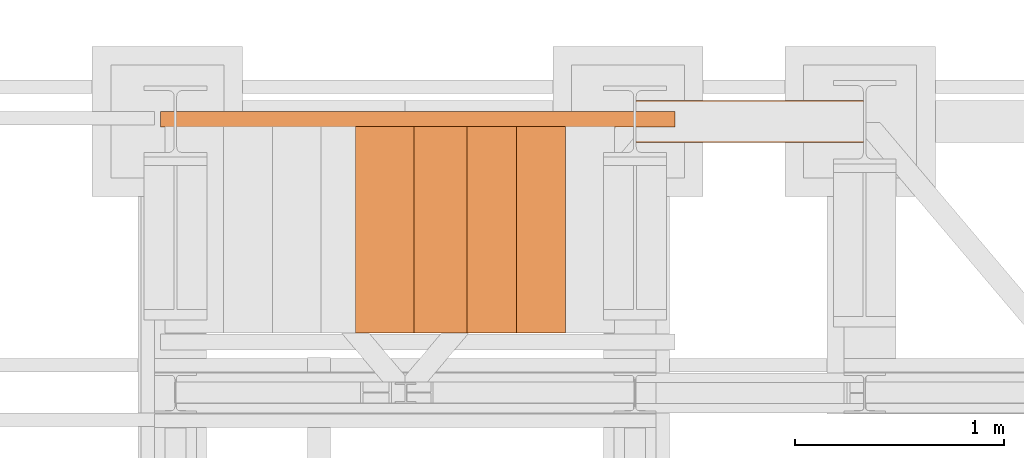
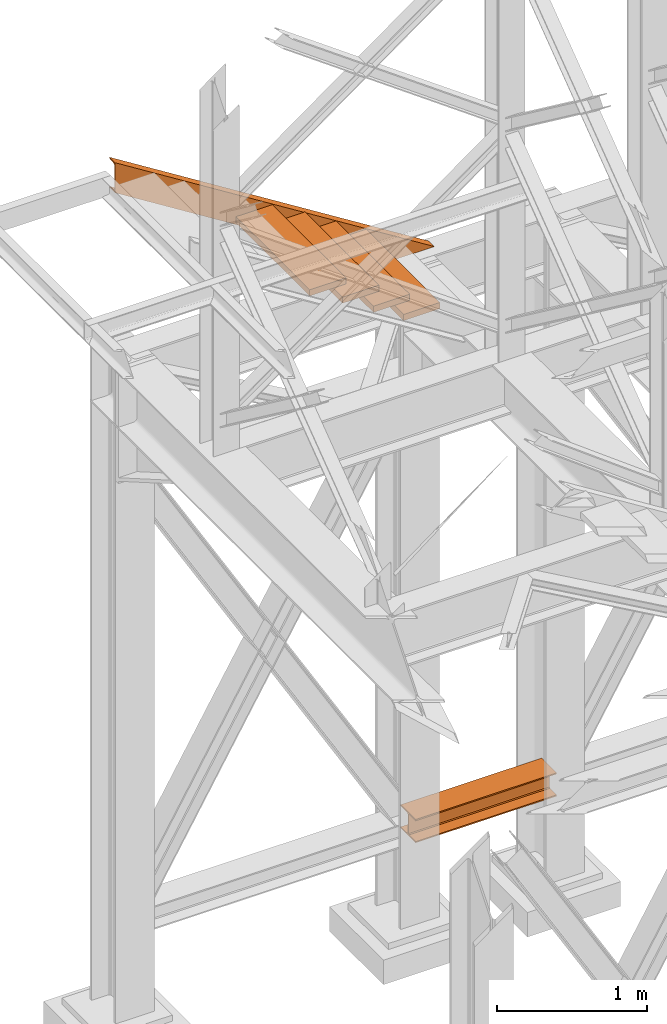
# One storey, part 135 of 208: 6 proxies.
"""IFC2X3 building model written with IfcOpenShell, lengths in millimetres."""

import ifcopenshell
import ifcopenshell.guid

model = None  # the IFC model being written
_history = None  # IfcOwnerHistory: only IFC2X3 demands one
_inside = {}  # id of a spatial element -> (the spatial element, [elements in it])
_under = {}  # id of a project, library or spatial element -> (it, [spatial elements below it])
_declared = {}  # id of a project -> (the project, [libraries it declares])
_typed = {}  # id of a type object -> (the type object, [elements of that type])
_made_of = {}  # id of a material, layer set ... -> (it, [elements and type objects made of it])


def new_model(schema):
    """Start an empty IFC model of exactly this schema.

    Asked for "IFC4X3", IfcOpenShell would pick the latest addendum, in which some entities
    have other attributes; the version numbers below select the first issue.
    IFC2X3 requires an IfcOwnerHistory on every rooted entity: one is made here for all.
    """
    global model, _history
    if schema == "IFC4X3":
        model = ifcopenshell.file(schema_version=(4, 3, 0, 0))
    else:
        model = ifcopenshell.file(schema=schema)
    _inside.clear()
    _under.clear()
    _declared.clear()
    _typed.clear()
    _made_of.clear()
    _history = None
    if model.schema == "IFC2X3":
        org = make("IfcOrganization", Name="unknown")
        user = make(
            "IfcPersonAndOrganization",
            ThePerson=make("IfcPerson", FamilyName="unknown"),
            TheOrganization=org,
        )
        app = make(
            "IfcApplication",
            ApplicationDeveloper=org,
            Version="unknown",
            ApplicationFullName="unknown",
            ApplicationIdentifier="unknown",
        )
        _history = make(
            "IfcOwnerHistory",
            OwningUser=user,
            OwningApplication=app,
            ChangeAction="ADDED",
            CreationDate=0,
        )
    return model


def make(cls, **values):
    """One entity of the class cls with the attributes given. An attribute that is None is left unset."""
    return model.create_entity(
        cls, **{name: value for name, value in values.items() if value is not None}
    )


def entity(cls, *values):
    """Any entity or typed value of the class cls, its attributes in the order of the schema. None: left unset."""
    e = model.create_entity(cls)
    for i, value in enumerate(values):
        if value is not None:
            e[i] = value
    return e


def rooted(cls, **values):
    """An entity with a GlobalId (a new one), such as an element, a storey or a relation."""
    return make(cls, GlobalId=ifcopenshell.guid.new(), OwnerHistory=_history, **values)


def si_unit(unit_type, name, prefix=None):
    """IfcSIUnit, for example si_unit("LENGTHUNIT", "METRE", prefix="MILLI")."""
    return make("IfcSIUnit", UnitType=unit_type, Prefix=prefix, Name=name)


def converted_unit(unit_type, name, factor, base, dimensions=None, offset=None):
    """IfcConversionBasedUnit, such as the inch: factor (a typed value) times the base unit."""
    return make(
        "IfcConversionBasedUnit"
        if offset is None
        else "IfcConversionBasedUnitWithOffset",
        ConversionOffset=offset,
        Dimensions=None
        if dimensions is None
        else entity("IfcDimensionalExponents", *dimensions),
        UnitType=unit_type,
        Name=name,
        ConversionFactor=make(
            "IfcMeasureWithUnit", ValueComponent=factor, UnitComponent=base
        ),
    )


def assignment(units):
    """IfcUnitAssignment: the units of a project."""
    return None if units is None else make("IfcUnitAssignment", Units=units)


def point(xyz):
    """IfcCartesianPoint."""
    return None if xyz is None else make("IfcCartesianPoint", Coordinates=xyz)


def direction(xyz):
    """IfcDirection."""
    return None if xyz is None else make("IfcDirection", DirectionRatios=xyz)


def frame(location, z_axis=None, x_axis=None):
    """IfcAxis2Placement3D, a coordinate frame: its origin and axes. An axis left out is left unset."""
    return make(
        "IfcAxis2Placement3D",
        Location=point(location),
        Axis=direction(z_axis),
        RefDirection=direction(x_axis),
    )


def origin():
    """The frame at (0, 0, 0) with its axes left unset."""
    return frame((0.0, 0.0, 0.0))


def origin_with_axes():
    """The frame at (0, 0, 0) with the z axis (0, 0, 1) and the x axis (1, 0, 0) written out."""
    return frame((0.0, 0.0, 0.0), z_axis=(0.0, 0.0, 1.0), x_axis=(1.0, 0.0, 0.0))


def place(relative_to, where):
    """IfcLocalPlacement: puts the frame where relative to a parent placement (None: the world)."""
    return make(
        "IfcLocalPlacement", PlacementRelTo=relative_to, RelativePlacement=where
    )


def context(
    kind, dimensions, precision=None, world=None, true_north=None, identifier=None
):
    """IfcGeometricRepresentationContext, for example the 3D "Model" context."""
    return make(
        "IfcGeometricRepresentationContext",
        ContextIdentifier=identifier,
        ContextType=kind,
        CoordinateSpaceDimension=dimensions,
        Precision=precision,
        WorldCoordinateSystem=world,
        TrueNorth=true_north,
    )


def subcontext(parent, identifier, kind, view, scale=None):
    """IfcGeometricRepresentationSubContext, for example "Body" below "Model"."""
    return make(
        "IfcGeometricRepresentationSubContext",
        ContextIdentifier=identifier,
        ContextType=kind,
        ParentContext=parent,
        TargetScale=scale,
        TargetView=view,
    )


def project(units=None, contexts=None):
    """IfcProject with its units and contexts."""
    return rooted(
        "IfcProject",
        Name="project",
        RepresentationContexts=contexts,
        UnitsInContext=assignment(units),
    )


def spatial(cls, under=None, at=None, **own):
    """A site, building, storey or space (cls), placed at a placement, below another one or the project."""
    s = rooted(cls, ObjectPlacement=at, **own)
    if under is not None:
        _under.setdefault(under.id(), (under, []))[1].append(s)
    return s


def faces_of(points, faces, orient=None, outer=None):
    """IfcFace entities. A face is a list of loops; a loop is a list of indices into points, from 0.

    orient and outer hold one flag for each loop. By default every Orientation is true, the
    first loop of a face is its IfcFaceOuterBound and the others are IfcFaceBound.
    """
    made = []
    for i, loops in enumerate(faces):
        bounds = []
        for j, loop in enumerate(loops):
            is_outer = j == 0 if outer is None else outer[i][j]
            bounds.append(
                make(
                    "IfcFaceOuterBound" if is_outer else "IfcFaceBound",
                    Bound=make("IfcPolyLoop", Polygon=[points[k] for k in loop]),
                    Orientation=True if orient is None else orient[i][j],
                )
            )
        made.append(make("IfcFace", Bounds=bounds))
    return made


def faceted_brep(points, faces, orient=None, outer=None, voids=None):
    """IfcFacetedBrep: a solid bounded by flat faces; with voids (closed shells), ...WithVoids."""
    shared = [point(p) for p in points]
    hull = make("IfcClosedShell", CfsFaces=faces_of(shared, faces, orient, outer))
    if voids is None:
        return make("IfcFacetedBrep", Outer=hull)
    return make(
        "IfcFacetedBrepWithVoids",
        Outer=hull,
        Voids=[
            make(cls, CfsFaces=faces_of(shared, fs, o, b)) for cls, fs, o, b in voids
        ],
    )


def shape(context_of_items, identifier, shape_type, items):
    """IfcShapeRepresentation: the items that make up one representation, for example the "Body"."""
    return make(
        "IfcShapeRepresentation",
        ContextOfItems=context_of_items,
        RepresentationIdentifier=identifier,
        RepresentationType=shape_type,
        Items=items,
    )


def made_of(thing, what):
    """Note that an element or type object is made of a material, layer set ...; save() writes the relation."""
    if what is not None:
        _made_of.setdefault(what.id(), (what, []))[1].append(thing)
    return thing


def element(
    cls,
    number,
    at=None,
    inside=None,
    cuts=None,
    type_object=None,
    material=None,
    context=None,
    identifier="Body",
    shape_type=None,
    held_by="IfcProductDefinitionShape",
    body=None,
    shapes=None,
    **own,
):
    """One element of the class cls, such as IfcWall. Its Tag is "e" and its number.

    at: its placement. inside: the storey or other place that contains it. cuts: it is an
    opening in that element (IfcRelVoidsElement). A single representation is given by context,
    identifier, shape_type and body (its items); several are given by shapes. held_by: the class
    of the entity that holds the representations. save() writes the other relations.
    """
    e = rooted(cls, Tag="e%d" % number, ObjectPlacement=at, **own)
    if body is not None:
        shapes = [shape(context, identifier, shape_type, body)]
    if shapes is not None:
        e.Representation = make(held_by, Representations=shapes)
    if inside is not None:
        _inside.setdefault(inside.id(), (inside, []))[1].append(e)
    if cuts is not None:
        rooted(
            "IfcRelVoidsElement", RelatingBuildingElement=cuts, RelatedOpeningElement=e
        )
    if type_object is not None:
        _typed.setdefault(type_object.id(), (type_object, []))[1].append(e)
    return made_of(e, material)


def aggregate(whole, parts):
    """IfcRelAggregates: a whole, such as a stair, and the parts it consists of."""
    return rooted("IfcRelAggregates", RelatingObject=whole, RelatedObjects=parts)


def save(model, path):
    """Write the relations noted so far, then the file.

    IfcRelAggregates (storeys below a building ...), IfcRelContainedInSpatialStructure (elements
    in a storey), IfcRelDefinesByType, IfcRelAssociatesMaterial and IfcRelDeclares: one each for
    every whole, place, type object, material and project.
    """
    for whole, parts in _under.values():
        aggregate(whole, parts)
    for where, things in _inside.values():
        rooted(
            "IfcRelContainedInSpatialStructure",
            RelatedElements=things,
            RelatingStructure=where,
        )
    for kind, things in _typed.values():
        rooted("IfcRelDefinesByType", RelatedObjects=things, RelatingType=kind)
    for what, things in _made_of.values():
        rooted("IfcRelAssociatesMaterial", RelatedObjects=things, RelatingMaterial=what)
    for by, libraries in _declared.values():
        rooted("IfcRelDeclares", RelatingContext=by, RelatedDefinitions=libraries)
    model.write(path)


model = new_model("IFC2X3")

# Units and contexts
model_context = context("Model", 3, precision=1e-05, world=origin())
plan_context = context("Plan", 3, precision=1e-05, world=origin())
body_context = subcontext(model_context, "Body", "Model", "MODEL_VIEW")
ifc_project = project(units=[si_unit("LENGTHUNIT", "METRE", prefix="MILLI"), converted_unit("PLANEANGLEUNIT", "DEGREE", entity("IfcPlaneAngleMeasure", 0.0174532925199433), si_unit("PLANEANGLEUNIT", "RADIAN"), dimensions=[0, 0, 0, 0, 0, 0, 0]), si_unit("AREAUNIT", "SQUARE_METRE"), si_unit("VOLUMEUNIT", "CUBIC_METRE")], contexts=[model_context, plan_context])

# Building, storey
building_placement = place(None, origin())
building = spatial("IfcBuilding", under=ifc_project, at=building_placement, CompositionType="COMPLEX")
storey_placement = place(building_placement, origin_with_axes())
storey = spatial("IfcBuildingStorey", under=building, at=storey_placement, Name="Geschoss", CompositionType="ELEMENT")

# Proxies
proxy_1_placement = place(storey_placement, frame((-1100.745031419175, -12562.57439501763, 544.9900024165573), z_axis=(0.0, 0.0, 1.0), x_axis=(1.0, 0.0, 0.0)))
element("IfcBuildingElementProxy", 1, at=proxy_1_placement, inside=storey, context=body_context, shape_type="Brep", body=[
    faceted_brep([(1088.009999895692, 0.01000000000021828, 190.0100125169755), (1088.009999895692, 200.0100029802325, 190.0100125169755), (1088.009999895692, 200.0100029802325, 180.0100146031381), (1088.009999895692, 121.2600035762789, 180.0100071525575), (1088.009999895692, 111.9441915473344, 178.1454621052743), (1088.009999895692, 105.1245498640838, 171.3258190250398), (1088.009999895692, 103.2600015571716, 162.0100079274179), (1088.009999895692, 103.2600015571716, 28.00999713897716), (1088.009999895692, 105.1245498640838, 18.69418604135524), (1088.009999895692, 111.9441915473344, 11.87454296112071), (1088.009999895692, 121.2600035762789, 10.00999791383754), (1088.009999895692, 200.0100029802325, 10.00999791383754), (1088.009999895692, 200.0100029802325, 0.01000000000010459), (1088.009999895692, 0.01000000000021828, 0.01000000000010459), (1088.009999895692, 0.01000000000021828, 10.00999791383754), (1088.009999895692, 78.75999940395377, 10.00999791383754), (1088.009999895692, 88.07581143289826, 11.87454296112071), (1088.009999895692, 94.89545311614893, 18.69418604135524), (1088.009999895692, 96.76000142306111, 28.00999713897716), (1088.009999895692, 96.76000142306111, 162.0100079274179), (1088.009999895692, 94.89545311614893, 171.3258190250398), (1088.009999895692, 88.07581143289826, 178.1454621052743), (1088.009999895692, 78.75999940395377, 180.0100071525575), (1088.009999895692, 0.01000000000021828, 180.0100146031381), (1088.009999895692, 200.0100029802325, 190.0100125169755), (1088.009999895692, 0.01000000000021828, 190.0100125169755), (0.009999999999990905, 0.01000000000021828, 190.0100125169754), (0.009999999999990905, 200.0100029802325, 190.0100125169754), (1088.009999895692, 200.0100029802325, 180.0100146031381), (1088.009999895692, 200.0100029802325, 190.0100125169755), (0.009999999999990905, 200.0100029802325, 190.0100125169754), (0.009999999999990905, 200.0100029802325, 180.010014603138), (1088.009999895692, 121.2600035762789, 180.0100071525575), (1088.009999895692, 200.0100029802325, 180.0100146031381), (0.009999999999990905, 200.0100029802325, 180.010014603138), (0.009999999999990905, 121.2600035762789, 180.0100071525574), (1088.009999895692, 111.9441915473344, 178.1454621052743), (1088.009999895692, 121.2600035762789, 180.0100071525575), (0.009999999999990905, 121.2600035762789, 180.0100071525574), (0.009999999999990905, 111.9441915473344, 178.1454621052742), (1088.009999895692, 105.1245498640838, 171.3258190250398), (1088.009999895692, 111.9441915473344, 178.1454621052743), (0.009999999999990905, 111.9441915473344, 178.1454621052742), (0.009999999999990905, 105.1245498640838, 171.3258190250397), (1088.009999895692, 103.2600015571716, 162.0100079274179), (1088.009999895692, 105.1245498640838, 171.3258190250398), (0.009999999999990905, 105.1245498640838, 171.3258190250397), (0.009999999999990905, 103.2600015571716, 162.0100079274178), (1088.009999895692, 103.2600015571716, 28.00999713897716), (1088.009999895692, 103.2600015571716, 162.0100079274179), (0.009999999999990905, 103.2600015571716, 162.0100079274178), (0.009999999999990905, 103.2600015571716, 28.00999713897704), (1088.009999895692, 105.1245498640838, 18.69418604135524), (1088.009999895692, 103.2600015571716, 28.00999713897716), (0.009999999999990905, 103.2600015571716, 28.00999713897704), (0.009999999999990905, 105.1245498640838, 18.69418604135512), (1088.009999895692, 111.9441915473344, 11.87454296112071), (1088.009999895692, 105.1245498640838, 18.69418604135524), (0.009999999999990905, 105.1245498640838, 18.69418604135512), (0.009999999999990905, 111.9441915473344, 11.8745429611206), (1088.009999895692, 121.2600035762789, 10.00999791383754), (1088.009999895692, 111.9441915473344, 11.87454296112071), (0.009999999999990905, 111.9441915473344, 11.8745429611206), (0.009999999999990905, 121.2600035762789, 10.00999791383742), (1088.009999895692, 200.0100029802325, 10.00999791383754), (1088.009999895692, 121.2600035762789, 10.00999791383754), (0.009999999999990905, 121.2600035762789, 10.00999791383742), (0.009999999999990905, 200.0100029802325, 10.00999791383742), (1088.009999895692, 200.0100029802325, 0.01000000000010459), (1088.009999895692, 200.0100029802325, 10.00999791383754), (0.009999999999990905, 200.0100029802325, 10.00999791383742), (0.009999999999990905, 200.0100029802325, 0.009999999999990905), (1088.009999895692, 0.01000000000021828, 0.01000000000010459), (1088.009999895692, 200.0100029802325, 0.01000000000010459), (0.009999999999990905, 200.0100029802325, 0.009999999999990905), (0.009999999999990905, 0.01000000000021828, 0.009999999999990905), (1088.009999895692, 0.01000000000021828, 10.00999791383754), (1088.009999895692, 0.01000000000021828, 0.01000000000010459), (0.009999999999990905, 0.01000000000021828, 0.009999999999990905), (0.009999999999990905, 0.01000000000021828, 10.00999791383742), (1088.009999895692, 78.75999940395377, 10.00999791383754), (1088.009999895692, 0.01000000000021828, 10.00999791383754), (0.009999999999990905, 0.01000000000021828, 10.00999791383742), (0.009999999999990905, 78.75999940395377, 10.00999791383742), (1088.009999895692, 88.07581143289826, 11.87454296112071), (1088.009999895692, 78.75999940395377, 10.00999791383754), (0.009999999999990905, 78.75999940395377, 10.00999791383742), (0.009999999999990905, 88.07581143289826, 11.8745429611206), (1088.009999895692, 94.89545311614893, 18.69418604135524), (1088.009999895692, 88.07581143289826, 11.87454296112071), (0.009999999999990905, 88.07581143289826, 11.8745429611206), (0.009999999999990905, 94.89545311614893, 18.69418604135512), (1088.009999895692, 96.76000142306111, 28.00999713897716), (1088.009999895692, 94.89545311614893, 18.69418604135524), (0.009999999999990905, 94.89545311614893, 18.69418604135512), (0.009999999999990905, 96.76000142306111, 28.00999713897704), (1088.009999895692, 96.76000142306111, 162.0100079274179), (1088.009999895692, 96.76000142306111, 28.00999713897716), (0.009999999999990905, 96.76000142306111, 28.00999713897704), (0.009999999999990905, 96.76000142306111, 162.0100079274178), (1088.009999895692, 94.89545311614893, 171.3258190250398), (1088.009999895692, 96.76000142306111, 162.0100079274179), (0.009999999999990905, 96.76000142306111, 162.0100079274178), (0.009999999999990905, 94.89545311614893, 171.3258190250397), (1088.009999895692, 88.07581143289826, 178.1454621052743), (1088.009999895692, 94.89545311614893, 171.3258190250398), (0.009999999999990905, 94.89545311614893, 171.3258190250397), (0.009999999999990905, 88.07581143289826, 178.1454621052742), (1088.009999895692, 78.75999940395377, 180.0100071525575), (1088.009999895692, 88.07581143289826, 178.1454621052743), (0.009999999999990905, 88.07581143289826, 178.1454621052742), (0.009999999999990905, 78.75999940395377, 180.0100071525574), (1088.009999895692, 0.01000000000021828, 180.0100146031381), (1088.009999895692, 78.75999940395377, 180.0100071525575), (0.009999999999990905, 78.75999940395377, 180.0100071525574), (0.009999999999990905, 0.01000000000021828, 180.010014603138), (1088.009999895692, 0.01000000000021828, 190.0100125169755), (1088.009999895692, 0.01000000000021828, 180.0100146031381), (0.009999999999990905, 0.01000000000021828, 180.010014603138), (0.009999999999990905, 0.01000000000021828, 190.0100125169754), (0.009999999999990905, 0.01000000000021828, 190.0100125169754), (0.009999999999990905, 0.01000000000021828, 180.010014603138), (0.009999999999990905, 78.75999940395377, 180.0100071525574), (0.009999999999990905, 88.07581143289826, 178.1454621052742), (0.009999999999990905, 94.89545311614893, 171.3258190250397), (0.009999999999990905, 96.76000142306111, 162.0100079274178), (0.009999999999990905, 96.76000142306111, 28.00999713897704), (0.009999999999990905, 94.89545311614893, 18.69418604135512), (0.009999999999990905, 88.07581143289826, 11.8745429611206), (0.009999999999990905, 78.75999940395377, 10.00999791383742), (0.009999999999990905, 0.01000000000021828, 10.00999791383742), (0.009999999999990905, 0.01000000000021828, 0.009999999999990905), (0.009999999999990905, 200.0100029802325, 0.009999999999990905), (0.009999999999990905, 200.0100029802325, 10.00999791383742), (0.009999999999990905, 121.2600035762789, 10.00999791383742), (0.009999999999990905, 111.9441915473344, 11.8745429611206), (0.009999999999990905, 105.1245498640838, 18.69418604135512), (0.009999999999990905, 103.2600015571716, 28.00999713897704), (0.009999999999990905, 103.2600015571716, 162.0100079274178), (0.009999999999990905, 105.1245498640838, 171.3258190250397), (0.009999999999990905, 111.9441915473344, 178.1454621052742), (0.009999999999990905, 121.2600035762789, 180.0100071525574), (0.009999999999990905, 200.0100029802325, 180.010014603138), (0.009999999999990905, 200.0100029802325, 190.0100125169754)], [[[0, 1, 2, 3, 4, 5, 6, 7, 8, 9, 10, 11, 12, 13, 14, 15, 16, 17, 18, 19, 20, 21, 22, 23]], [[24, 25, 26, 27]], [[28, 29, 30, 31]], [[32, 33, 34, 35]], [[36, 37, 38, 39]], [[40, 41, 42, 43]], [[44, 45, 46, 47]], [[48, 49, 50, 51]], [[52, 53, 54, 55]], [[56, 57, 58, 59]], [[60, 61, 62, 63]], [[64, 65, 66, 67]], [[68, 69, 70, 71]], [[72, 73, 74, 75]], [[76, 77, 78, 79]], [[80, 81, 82, 83]], [[84, 85, 86, 87]], [[88, 89, 90, 91]], [[92, 93, 94, 95]], [[96, 97, 98, 99]], [[100, 101, 102, 103]], [[104, 105, 106, 107]], [[108, 109, 110, 111]], [[112, 113, 114, 115]], [[116, 117, 118, 119]], [[120, 121, 122, 123, 124, 125, 126, 127, 128, 129, 130, 131, 132, 133, 134, 135, 136, 137, 138, 139, 140, 141, 142, 143]]], orient=[[False], [False], [False], [False], [False], [False], [False], [False], [False], [False], [False], [False], [False], [False], [False], [False], [False], [False], [False], [False], [False], [False], [False], [False], [False], [False]]),
])
proxy_2_placement = place(storey_placement, frame((-3377.982231929545, -12489.73706339187, 5299.235995667714), z_axis=(0.0, 0.0, 1.0), x_axis=(1.0, 0.0, 0.0)))
element("IfcBuildingElementProxy", 2, at=proxy_2_placement, inside=storey, context=body_context, shape_type="Brep", body=[
    faceted_brep([(0.01000000000021828, 0.01000000000021828, 1301.03525473074), (0.01000000000021828, 0.01000000000021828, 1546.598640795312), (2463.776225798724, 0.01000000000021828, 0.01000000000294676), (2072.585730200911, 0.01000000000021828, 0.01000000000294676), (0.01000000000021828, 0.01000000000021828, 1546.598640795312), (0.01000000000021828, 75.01000111758731, 1546.598640795312), (2463.776225798724, 75.01000111758731, 0.01000000000294676), (2463.776225798724, 0.01000000000021828, 0.01000000000294676), (0.01000000000021828, 75.01000111758731, 1546.598640795312), (0.01000000000021828, 75.01000111758731, 1542.963282509619), (2457.984981296655, 75.01000111758731, 0.01000000000294676), (2463.776225798724, 75.01000111758731, 0.01000000000294676), (0.01000000000021828, 75.01000111758731, 1542.963282509619), (0.01000000000021828, 73.89400100171588, 1537.56333977627), (2449.382696127384, 73.89400100171588, 0.01000000000203727), (2457.984981296655, 75.01000111758731, 0.01000000000294676), (0.01000000000021828, 73.89400100171588, 1537.56333977627), (0.01000000000021828, 69.48847269475482, 1535.619839744783), (2446.28663709067, 69.48847269475482, 0.01000000000385626), (2449.382696127384, 73.89400100171588, 0.01000000000203727), (0.01000000000021828, 69.48847269475482, 1535.619839744783), (0.01000000000021828, 19.09293180167697, 1530.66971995284), (2438.400934561024, 19.09293180167697, 0.01000000000294676), (2446.28663709067, 69.48847269475482, 0.01000000000385626), (0.01000000000021828, 19.09293180167697, 1530.66971995284), (0.01000000000021828, 13.35380079060815, 1528.711080065991), (2435.280757240155, 13.35380079060815, 0.01000000000021828), (2438.400934561024, 19.09293180167697, 0.01000000000294676), (0.01000000000021828, 13.35380079060815, 1528.711080065991), (0.01000000000021828, 9.50015002697728, 1523.455656628751), (2426.908696030465, 9.50015002697728, 0.01000000000294676), (2435.280757240155, 13.35380079060815, 0.01000000000021828), (0.01000000000021828, 9.50015002697728, 1523.455656628751), (0.01000000000021828, 8.510000461936215, 1516.594795610196), (2415.979120310368, 8.510000461936215, 0.01000000000294676), (2426.908696030465, 9.50015002697728, 0.01000000000294676), (0.01000000000021828, 8.510000461936215, 1516.594795610196), (0.01000000000021828, 8.510000461936215, 1331.039099915858), (2120.382835689267, 8.510000461936215, 0.01000000000294676), (2415.979120310368, 8.510000461936215, 0.01000000000294676), (0.01000000000021828, 8.510000461936215, 1331.039099915858), (0.01000000000021828, 9.50015002697728, 1324.178238897302), (2109.453259969165, 9.50015002697728, 0.01000000000294676), (2120.382835689267, 8.510000461936215, 0.01000000000294676), (0.01000000000021828, 9.50015002697728, 1324.178238897302), (0.01000000000021828, 13.35380079060815, 1318.922815460061), (2101.081198759479, 13.35380079060815, 0.01000000000294676), (2109.453259969165, 9.50015002697728, 0.01000000000294676), (0.01000000000021828, 13.35380079060815, 1318.922815460061), (0.01000000000021828, 19.09293180167697, 1316.964175573211), (2097.96102143861, 19.09293180167697, 0.01000000000385626), (2101.081198759479, 13.35380079060815, 0.01000000000294676), (0.01000000000021828, 19.09293180167697, 1316.964175573211), (0.01000000000021828, 69.48847269475482, 1312.014055781273), (2090.075318908967, 69.48847269475482, 0.01000000000203727), (2097.96102143861, 19.09293180167697, 0.01000000000385626), (0.01000000000021828, 69.48847269475482, 1312.014055781273), (0.01000000000021828, 73.89400100171588, 1310.070555749785), (2086.97925987225, 73.89400100171588, 0.01000000000476575), (2090.075318908967, 69.48847269475482, 0.01000000000203727), (0.01000000000021828, 73.89400100171588, 1310.070555749785), (0.01000000000021828, 75.01000111758731, 1304.670613016434), (2078.376974702981, 75.01000111758731, 0.01000000000294676), (2086.97925987225, 73.89400100171588, 0.01000000000476575), (0.01000000000021828, 75.01000111758731, 1304.670613016434), (0.01000000000021828, 75.01000111758731, 1301.03525473074), (2072.585730200911, 75.01000111758731, 0.01000000000294676), (2078.376974702981, 75.01000111758731, 0.01000000000294676), (0.01000000000021828, 75.01000111758731, 1301.03525473074), (0.01000000000021828, 0.01000000000021828, 1301.03525473074), (2072.585730200911, 0.01000000000021828, 0.01000000000294676), (2072.585730200911, 75.01000111758731, 0.01000000000294676), (0.01000000000021828, 0.01000000000021828, 1301.03525473074), (0.01000000000021828, 75.01000111758731, 1301.03525473074), (0.01000000000021828, 75.01000111758731, 1304.670613016434), (0.01000000000021828, 73.89400100171588, 1310.070555749785), (0.01000000000021828, 69.48847269475482, 1312.014055781273), (0.01000000000021828, 19.09293180167697, 1316.964175573211), (0.01000000000021828, 13.35380079060815, 1318.922815460061), (0.01000000000021828, 9.50015002697728, 1324.178238897302), (0.01000000000021828, 8.510000461936215, 1331.039099915858), (0.01000000000021828, 8.510000461936215, 1516.594795610196), (0.01000000000021828, 9.50015002697728, 1523.455656628751), (0.01000000000021828, 13.35380079060815, 1528.711080065991), (0.01000000000021828, 19.09293180167697, 1530.66971995284), (0.01000000000021828, 69.48847269475482, 1535.619839744783), (0.01000000000021828, 73.89400100171588, 1537.56333977627), (0.01000000000021828, 75.01000111758731, 1542.963282509619), (0.01000000000021828, 75.01000111758731, 1546.598640795312), (0.01000000000021828, 0.01000000000021828, 1546.598640795312), (2072.585730200911, 0.01000000000021828, 0.01000000000294676), (2463.776225798724, 0.01000000000021828, 0.01000000000294676), (2463.776225798724, 75.01000111758731, 0.01000000000294676), (2457.984981296655, 75.01000111758731, 0.01000000000294676), (2449.382696127384, 73.89400100171588, 0.01000000000203727), (2446.28663709067, 69.48847269475482, 0.01000000000385626), (2438.400934561024, 19.09293180167697, 0.01000000000294676), (2435.280757240155, 13.35380079060815, 0.01000000000021828), (2426.908696030465, 9.50015002697728, 0.01000000000294676), (2415.979120310368, 8.510000461936215, 0.01000000000294676), (2120.382835689267, 8.510000461936215, 0.01000000000294676), (2109.453259969165, 9.50015002697728, 0.01000000000294676), (2101.081198759479, 13.35380079060815, 0.01000000000294676), (2097.96102143861, 19.09293180167697, 0.01000000000385626), (2090.075318908967, 69.48847269475482, 0.01000000000203727), (2086.97925987225, 73.89400100171588, 0.01000000000476575), (2078.376974702981, 75.01000111758731, 0.01000000000294676), (2072.585730200911, 75.01000111758731, 0.01000000000294676)], [[[0, 1, 2, 3]], [[4, 5, 6, 7]], [[8, 9, 10, 11]], [[12, 13, 14, 15]], [[16, 17, 18, 19]], [[20, 21, 22, 23]], [[24, 25, 26, 27]], [[28, 29, 30, 31]], [[32, 33, 34, 35]], [[36, 37, 38, 39]], [[40, 41, 42, 43]], [[44, 45, 46, 47]], [[48, 49, 50, 51]], [[52, 53, 54, 55]], [[56, 57, 58, 59]], [[60, 61, 62, 63]], [[64, 65, 66, 67]], [[68, 69, 70, 71]], [[72, 73, 74, 75, 76, 77, 78, 79, 80, 81, 82, 83, 84, 85, 86, 87, 88, 89]], [[90, 91, 92, 93, 94, 95, 96, 97, 98, 99, 100, 101, 102, 103, 104, 105, 106, 107]]], orient=[[False], [False], [False], [False], [False], [False], [False], [False], [False], [False], [False], [False], [False], [False], [False], [False], [False], [False], [False], [False]]),
])
proxy_3_placement = place(storey_placement, frame((-2191.97451080468, -13474.7262510599, 5880.987947857569), z_axis=(0.0, 0.0, 1.0), x_axis=(1.0, 0.0, 0.0)))
element("IfcBuildingElementProxy", 3, at=proxy_3_placement, inside=storey, context=body_context, shape_type="Brep", body=[
    faceted_brep([(0.009999999999763531, 0.01000000000021828, 0.01000000000021828), (280.2746556316172, 0.01000000000021828, 0.01000000000021828), (280.2746556316172, 988.9080206708586, 0.01000000000021828), (0.009999999999763531, 988.9080206708586, 0.01000000000021828), (280.2746556316172, 0.01000000000021828, 50.01000000000022), (0.009999999999763531, 0.01000000000021828, 50.01000000000022), (0.009999999999763531, 988.9080206708586, 50.01000000000022), (280.2746556316172, 988.9080206708586, 50.01000000000022), (280.2746556316172, 0.01000000000021828, 0.01000000000021828), (0.009999999999763531, 0.01000000000021828, 0.01000000000021828), (0.009999999999763531, 0.01000000000021828, 50.01000000000022), (280.2746556316172, 0.01000000000021828, 50.01000000000022), (280.2746556316172, 988.9080206708586, 0.01000000000021828), (280.2746556316172, 0.01000000000021828, 0.01000000000021828), (280.2746556316172, 0.01000000000021828, 50.01000000000022), (280.2746556316172, 988.9080206708586, 50.01000000000022), (0.009999999999763531, 988.9080206708586, 0.01000000000021828), (280.2746556316172, 988.9080206708586, 0.01000000000021828), (280.2746556316172, 988.9080206708586, 50.01000000000022), (0.009999999999763531, 988.9080206708586, 50.01000000000022), (0.009999999999763531, 0.01000000000021828, 0.01000000000021828), (0.009999999999763531, 988.9080206708586, 0.01000000000021828), (0.009999999999763531, 988.9080206708586, 50.01000000000022), (0.009999999999763531, 0.01000000000021828, 50.01000000000022)], [[[0, 1, 2, 3]], [[4, 5, 6, 7]], [[8, 9, 10, 11]], [[12, 13, 14, 15]], [[16, 17, 18, 19]], [[20, 21, 22, 23]]], orient=[[False], [False], [False], [False], [False], [False]]),
])
proxy_4_placement = place(storey_placement, frame((-1953.400600323233, -13474.7262510599, 5723.648884501375), z_axis=(0.0, 0.0, 1.0), x_axis=(1.0, 0.0, 0.0)))
element("IfcBuildingElementProxy", 4, at=proxy_4_placement, inside=storey, context=body_context, shape_type="Brep", body=[
    faceted_brep([(0.009999999999990905, 0.01000000000021828, 0.01000000000021828), (280.2746556316176, 0.01000000000021828, 0.01000000000021828), (280.2746556316176, 988.9080206708586, 0.01000000000021828), (0.009999999999990905, 988.9080206708586, 0.01000000000021828), (280.2746556316176, 0.01000000000021828, 50.01000000000022), (0.009999999999990905, 0.01000000000021828, 50.01000000000022), (0.009999999999990905, 988.9080206708586, 50.01000000000022), (280.2746556316176, 988.9080206708586, 50.01000000000022), (280.2746556316176, 0.01000000000021828, 0.01000000000021828), (0.009999999999990905, 0.01000000000021828, 0.01000000000021828), (0.009999999999990905, 0.01000000000021828, 50.01000000000022), (280.2746556316176, 0.01000000000021828, 50.01000000000022), (280.2746556316176, 988.9080206708586, 0.01000000000021828), (280.2746556316176, 0.01000000000021828, 0.01000000000021828), (280.2746556316176, 0.01000000000021828, 50.01000000000022), (280.2746556316176, 988.9080206708586, 50.01000000000022), (0.009999999999990905, 988.9080206708586, 0.01000000000021828), (280.2746556316176, 988.9080206708586, 0.01000000000021828), (280.2746556316176, 988.9080206708586, 50.01000000000022), (0.009999999999990905, 988.9080206708586, 50.01000000000022), (0.009999999999990905, 0.01000000000021828, 0.01000000000021828), (0.009999999999990905, 988.9080206708586, 0.01000000000021828), (0.009999999999990905, 988.9080206708586, 50.01000000000022), (0.009999999999990905, 0.01000000000021828, 50.01000000000022)], [[[0, 1, 2, 3]], [[4, 5, 6, 7]], [[8, 9, 10, 11]], [[12, 13, 14, 15]], [[16, 17, 18, 19]], [[20, 21, 22, 23]]], orient=[[False], [False], [False], [False], [False], [False]]),
])
proxy_5_placement = place(storey_placement, frame((-2444.709211129622, -13474.7262510599, 6029.15245398457), z_axis=(0.0, 0.0, 1.0), x_axis=(1.0, 0.0, 0.0)))
element("IfcBuildingElementProxy", 5, at=proxy_5_placement, inside=storey, context=body_context, shape_type="Brep", body=[
    faceted_brep([(0.01000000000021828, 0.01000000000021828, 0.01000000000021828), (280.2746556316179, 0.01000000000021828, 0.01000000000021828), (280.2746556316179, 988.9080206708586, 0.01000000000021828), (0.01000000000021828, 988.9080206708586, 0.01000000000021828), (280.2746556316179, 0.01000000000021828, 50.01000000000022), (0.01000000000021828, 0.01000000000021828, 50.01000000000022), (0.01000000000021828, 988.9080206708586, 50.01000000000022), (280.2746556316179, 988.9080206708586, 50.01000000000022), (280.2746556316179, 0.01000000000021828, 0.01000000000021828), (0.01000000000021828, 0.01000000000021828, 0.01000000000021828), (0.01000000000021828, 0.01000000000021828, 50.01000000000022), (280.2746556316179, 0.01000000000021828, 50.01000000000022), (280.2746556316179, 988.9080206708586, 0.01000000000021828), (280.2746556316179, 0.01000000000021828, 0.01000000000021828), (280.2746556316179, 0.01000000000021828, 50.01000000000022), (280.2746556316179, 988.9080206708586, 50.01000000000022), (0.01000000000021828, 988.9080206708586, 0.01000000000021828), (280.2746556316179, 988.9080206708586, 0.01000000000021828), (280.2746556316179, 988.9080206708586, 50.01000000000022), (0.01000000000021828, 988.9080206708586, 50.01000000000022), (0.01000000000021828, 0.01000000000021828, 0.01000000000021828), (0.01000000000021828, 988.9080206708586, 0.01000000000021828), (0.01000000000021828, 988.9080206708586, 50.01000000000022), (0.01000000000021828, 0.01000000000021828, 50.01000000000022)], [[[0, 1, 2, 3]], [[4, 5, 6, 7]], [[8, 9, 10, 11]], [[12, 13, 14, 15]], [[16, 17, 18, 19]], [[20, 21, 22, 23]]], orient=[[False], [False], [False], [False], [False], [False]]),
])
proxy_6_placement = place(storey_placement, frame((-1720.329412323669, -13474.7262510599, 5574.778373538034), z_axis=(0.0, 0.0, 1.0), x_axis=(1.0, 0.0, 0.0)))
element("IfcBuildingElementProxy", 6, at=proxy_6_placement, inside=storey, context=body_context, shape_type="Brep", body=[
    faceted_brep([(0.009999999999990905, 0.01000000000021828, 0.01000000000021828), (280.2746556316176, 0.01000000000021828, 0.01000000000021828), (280.2746556316176, 988.9080206708586, 0.01000000000021828), (0.009999999999990905, 988.9080206708586, 0.01000000000021828), (280.2746556316176, 0.01000000000021828, 50.01000000000022), (0.009999999999990905, 0.01000000000021828, 50.01000000000022), (0.009999999999990905, 988.9080206708586, 50.01000000000022), (280.2746556316176, 988.9080206708586, 50.01000000000022), (280.2746556316176, 0.01000000000021828, 0.01000000000021828), (0.009999999999990905, 0.01000000000021828, 0.01000000000021828), (0.009999999999990905, 0.01000000000021828, 50.01000000000022), (280.2746556316176, 0.01000000000021828, 50.01000000000022), (280.2746556316176, 988.9080206708586, 0.01000000000021828), (280.2746556316176, 0.01000000000021828, 0.01000000000021828), (280.2746556316176, 0.01000000000021828, 50.01000000000022), (280.2746556316176, 988.9080206708586, 50.01000000000022), (0.009999999999990905, 988.9080206708586, 0.01000000000021828), (280.2746556316176, 988.9080206708586, 0.01000000000021828), (280.2746556316176, 988.9080206708586, 50.01000000000022), (0.009999999999990905, 988.9080206708586, 50.01000000000022), (0.009999999999990905, 0.01000000000021828, 0.01000000000021828), (0.009999999999990905, 988.9080206708586, 0.01000000000021828), (0.009999999999990905, 988.9080206708586, 50.01000000000022), (0.009999999999990905, 0.01000000000021828, 50.01000000000022)], [[[0, 1, 2, 3]], [[4, 5, 6, 7]], [[8, 9, 10, 11]], [[12, 13, 14, 15]], [[16, 17, 18, 19]], [[20, 21, 22, 23]]], orient=[[False], [False], [False], [False], [False], [False]]),
])

save(model, "model.ifc")
